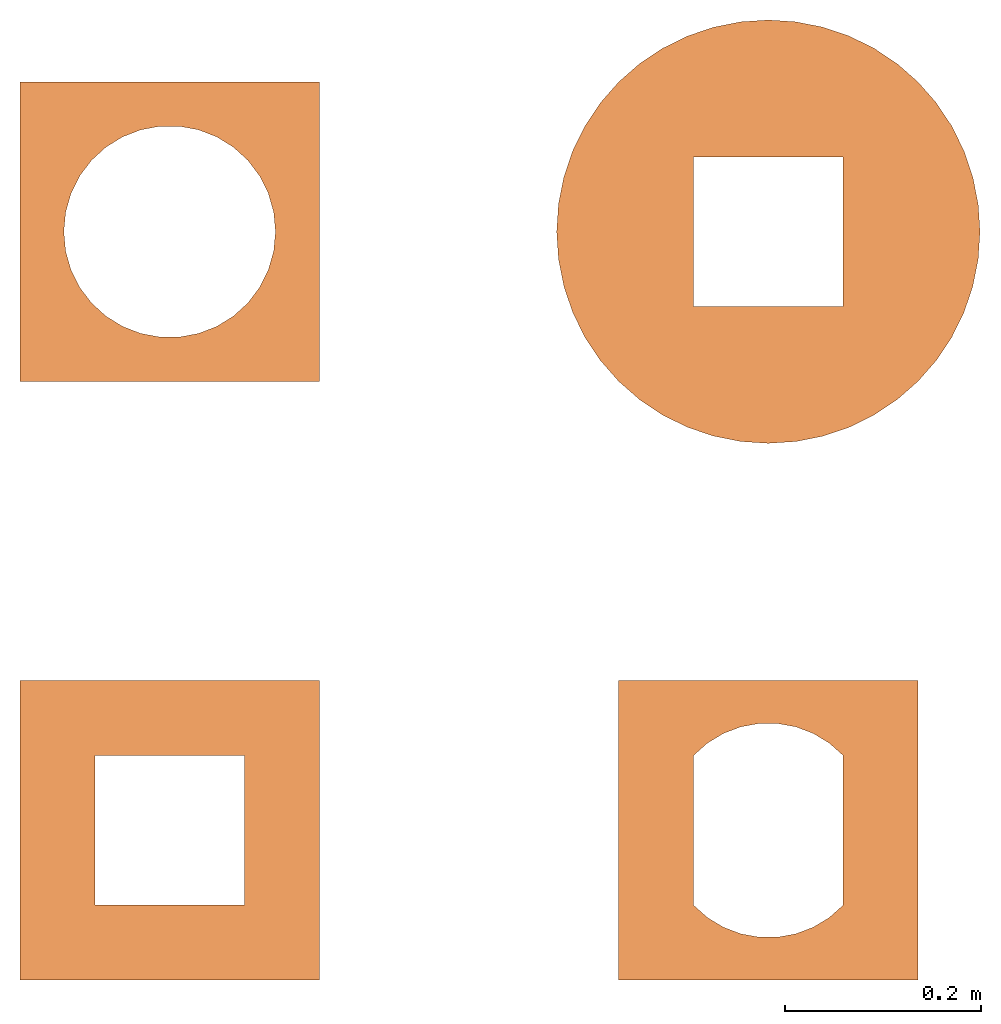
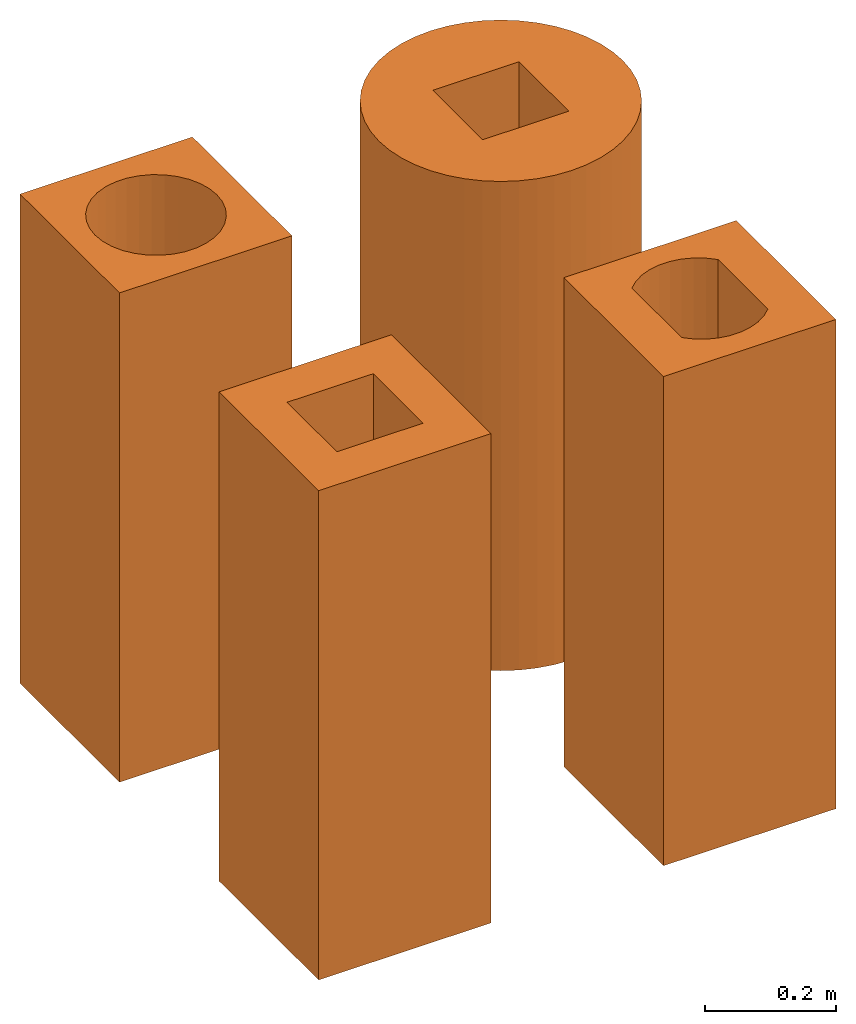
# One storey: 4 proxies.
"""IFC2X3 building model written with IfcOpenShell, lengths in feet."""

from ifc_helpers import new_model, entity, si_unit, converted_unit, derived_unit, direction, frame, frame_2d, origin, origin_2d_with_axis, place, context, subcontext, project, spatial, polyline, circle_curve, parameter, trimmed, segment, composite_curve, outline, extrude, source, transform, mapped, type_object, type_shapes, element, save


model = new_model("IFC2X3")

# Units and contexts
model_context = context("Model", 3, precision=0.0001, world=origin(), true_north=direction((6.12303176911189e-17, 1.0)))
body_context = subcontext(model_context, "Body", "Model", "MODEL_VIEW")
ifc_project = project(units=[converted_unit("LENGTHUNIT", "FOOT", entity("IfcRatioMeasure", 0.3048), si_unit("LENGTHUNIT", "METRE"), dimensions=[1, 0, 0, 0, 0, 0, 0]), converted_unit("AREAUNIT", "SQUARE FOOT", entity("IfcRatioMeasure", 0.09290304), si_unit("AREAUNIT", "SQUARE_METRE"), dimensions=[2, 0, 0, 0, 0, 0, 0]), converted_unit("VOLUMEUNIT", "CUBIC FOOT", entity("IfcRatioMeasure", 0.028316846592), si_unit("VOLUMEUNIT", "CUBIC_METRE"), dimensions=[3, 0, 0, 0, 0, 0, 0]), converted_unit("PLANEANGLEUNIT", "DEGREE", entity("IfcRatioMeasure", 0.0174532925199433), si_unit("PLANEANGLEUNIT", "RADIAN"), dimensions=[0, 0, 0, 0, 0, 0, 0]), si_unit("MASSUNIT", "GRAM", prefix="KILO"), derived_unit("MASSDENSITYUNIT", [(si_unit("MASSUNIT", "GRAM", prefix="KILO"), 1), (si_unit("LENGTHUNIT", "METRE"), -3)]), si_unit("TIMEUNIT", "SECOND"), si_unit("FREQUENCYUNIT", "HERTZ"), si_unit("THERMODYNAMICTEMPERATUREUNIT", "DEGREE_CELSIUS"), derived_unit("THERMALTRANSMITTANCEUNIT", [(si_unit("MASSUNIT", "GRAM", prefix="KILO"), 1), (si_unit("THERMODYNAMICTEMPERATUREUNIT", "KELVIN"), -1), (si_unit("TIMEUNIT", "SECOND"), -3)]), derived_unit("VOLUMETRICFLOWRATEUNIT", [(si_unit("LENGTHUNIT", "METRE"), 3), (si_unit("TIMEUNIT", "SECOND"), -1)]), si_unit("ELECTRICCURRENTUNIT", "AMPERE"), si_unit("ELECTRICVOLTAGEUNIT", "VOLT"), si_unit("POWERUNIT", "WATT"), si_unit("FORCEUNIT", "NEWTON"), si_unit("ILLUMINANCEUNIT", "LUX"), si_unit("LUMINOUSFLUXUNIT", "LUMEN"), si_unit("LUMINOUSINTENSITYUNIT", "CANDELA"), derived_unit("USERDEFINED", [(si_unit("MASSUNIT", "GRAM", prefix="KILO"), -1), (si_unit("LENGTHUNIT", "METRE"), -2), (si_unit("TIMEUNIT", "SECOND"), 3), (si_unit("LUMINOUSFLUXUNIT", "LUMEN"), 1)]), derived_unit("LINEARVELOCITYUNIT", [(si_unit("LENGTHUNIT", "METRE"), 1), (si_unit("TIMEUNIT", "SECOND"), -1)]), si_unit("PRESSUREUNIT", "PASCAL"), derived_unit("USERDEFINED", [(si_unit("LENGTHUNIT", "METRE"), -2), (si_unit("MASSUNIT", "GRAM", prefix="KILO"), 1), (si_unit("TIMEUNIT", "SECOND"), -2)])], contexts=[model_context])

# Site, building, storey
site_placement = place(None, origin())
site = spatial("IfcSite", under=ifc_project, at=site_placement, CompositionType="ELEMENT")
building_placement = place(site_placement, origin())
building = spatial("IfcBuilding", under=site, at=building_placement, CompositionType="ELEMENT")
storey_placement = place(building_placement, origin())
storey = spatial("IfcBuildingStorey", under=building, at=storey_placement, Name="Level 1", CompositionType="ELEMENT", Elevation=0.0)

# Proxies
building_element_proxy_type_1 = type_object("IfcBuildingElementProxyType", Name="Generic Models 1:Generic Models 1", PredefinedType="NOTDEFINED")
shared_shape_1 = source(origin(), body_context, "Body", "SweptSolid", [
    extrude(outline(polyline([(-0.5, -0.5), (0.5, -0.5), (0.5, 0.5), (-0.5, 0.5), (-0.5, -0.5)]), holes=[polyline([(-0.250000000000001, 0.25), (0.249999999999999, 0.25), (0.249999999999999, -0.25), (-0.250000000000001, -0.25), (-0.250000000000001, 0.25)])]), frame((0.5, 0.5, 0.0), z_axis=(0.0, 0.0, 1.0), x_axis=(-1.0, 0.0, 0.0)), (0.0, 0.0, 1.0), 3.0),
])
type_shapes(building_element_proxy_type_1, [shared_shape_1])
proxy_1_placement = place(storey_placement, origin())
element("IfcBuildingElementProxy", 1, at=proxy_1_placement, inside=storey, type_object=building_element_proxy_type_1, ObjectType="Generic Models 1 : Generic Models 1:Generic Models 1", context=body_context, shape_type="MappedRepresentation", body=[
    mapped(shared_shape_1, transform((0.0, 0.0, 0.0), scale=1.0)),
])
building_element_proxy_type_2 = type_object("IfcBuildingElementProxyType", Name="Generic Models 2:Generic Models 1", PredefinedType="NOTDEFINED")
shared_shape_2 = source(origin(), body_context, "Body", "SweptSolid", [
    extrude(outline(polyline([(-0.5, -0.499999999999997), (0.5, -0.499999999999997), (0.5, 0.499999999999997), (-0.5, 0.499999999999997), (-0.5, -0.499999999999997)]), holes=[composite_curve([segment(polyline([(-0.249999999999997, -0.249999999999999), (-0.25, 0.250000000000001)]), True, "CONTINUOUS"), segment(trimmed(circle_curve(frame_2d((0.0, 0.0156569919627089), x_axis=(-1.0, 0.0)), 0.342661123292337), [parameter(223.148487205105)], [parameter(316.851512794894)], True, "PARAMETER"), False, "CONTINUOUS"), segment(polyline([(0.25, 0.250000000000001), (0.25, -0.249999999999994)]), True, "CONTINUOUS"), segment(trimmed(circle_curve(frame_2d((0.0, -0.0156569919627043), x_axis=(-1.0, 0.0)), 0.342661123292337), [parameter(43.1484872051064)], [parameter(136.851512794895)], True, "PARAMETER"), False, "CONTINUOUS")], self_intersect=False)]), frame((2.5, 0.499999999999997, 0.0), z_axis=(0.0, 0.0, 1.0), x_axis=(-1.0, 0.0, 0.0)), (0.0, 0.0, 1.0), 3.0),
])
type_shapes(building_element_proxy_type_2, [shared_shape_2])
proxy_2_placement = place(storey_placement, origin())
element("IfcBuildingElementProxy", 2, at=proxy_2_placement, inside=storey, type_object=building_element_proxy_type_2, ObjectType="Generic Models 1 : Generic Models 2:Generic Models 1", context=body_context, shape_type="MappedRepresentation", body=[
    mapped(shared_shape_2, transform((0.0, 0.0, 0.0), scale=1.0)),
])
building_element_proxy_type_3 = type_object("IfcBuildingElementProxyType", Name="Generic Models 3:Generic Models 1", PredefinedType="NOTDEFINED")
shared_shape_3 = source(origin(), body_context, "Body", "SweptSolid", [
    extrude(outline(polyline([(-0.500000000000003, -0.5), (0.500000000000003, -0.5), (0.500000000000003, 0.5), (-0.500000000000003, 0.5), (-0.500000000000003, -0.5)]), holes=[composite_curve([segment(trimmed(circle_curve(frame_2d((0.0, 0.0), x_axis=(-1.0, 0.0)), 0.353553390593273), [parameter(180.0)], [parameter(0.0)], True, "PARAMETER"), False, "CONTINUOUS"), segment(trimmed(circle_curve(frame_2d((0.0, 0.0), x_axis=(-1.0, 0.0)), 0.353553390593273), [parameter(3.05333249420498e-13)], [parameter(180.0)], True, "PARAMETER"), False, "CONTINUOUS")], self_intersect=False)]), frame((0.500000000000003, 2.5, 0.0), z_axis=(0.0, 0.0, 1.0), x_axis=(-1.0, 0.0, 0.0)), (0.0, 0.0, 1.0), 3.0),
])
type_shapes(building_element_proxy_type_3, [shared_shape_3])
proxy_3_placement = place(storey_placement, origin())
element("IfcBuildingElementProxy", 3, at=proxy_3_placement, inside=storey, type_object=building_element_proxy_type_3, ObjectType="Generic Models 1 : Generic Models 3:Generic Models 1", context=body_context, shape_type="MappedRepresentation", body=[
    mapped(shared_shape_3, transform((0.0, 0.0, 0.0), scale=1.0)),
])
building_element_proxy_type_4 = type_object("IfcBuildingElementProxyType", Name="Generic Models 4:Generic Models 1", PredefinedType="NOTDEFINED")
shared_shape_4 = source(origin(), body_context, "Body", "SweptSolid", [
    extrude(outline(composite_curve([segment(trimmed(circle_curve(origin_2d_with_axis(), 0.707106781186551), [parameter(0.0)], [parameter(180.0)], True, "PARAMETER"), True, "CONTINUOUS"), segment(trimmed(circle_curve(origin_2d_with_axis(), 0.707106781186551), [parameter(180.0)], [parameter(360.0)], True, "PARAMETER"), True, "CONTINUOUS")], self_intersect=False), holes=[polyline([(0.250000000000001, -0.250000000000002), (-0.249999999999999, -0.250000000000002), (-0.249999999999999, 0.249999999999998), (0.250000000000001, 0.249999999999998), (0.250000000000001, -0.250000000000002)])]), frame((2.50000000000001, 2.49999999999999, 0.0)), (0.0, 0.0, 1.0), 3.0),
])
type_shapes(building_element_proxy_type_4, [shared_shape_4])
proxy_4_placement = place(storey_placement, origin())
element("IfcBuildingElementProxy", 4, at=proxy_4_placement, inside=storey, type_object=building_element_proxy_type_4, ObjectType="Generic Models 1 : Generic Models 4:Generic Models 1", context=body_context, shape_type="MappedRepresentation", body=[
    mapped(shared_shape_4, transform((0.0, 0.0, 0.0), scale=1.0)),
])

save(model, "model.ifc")
